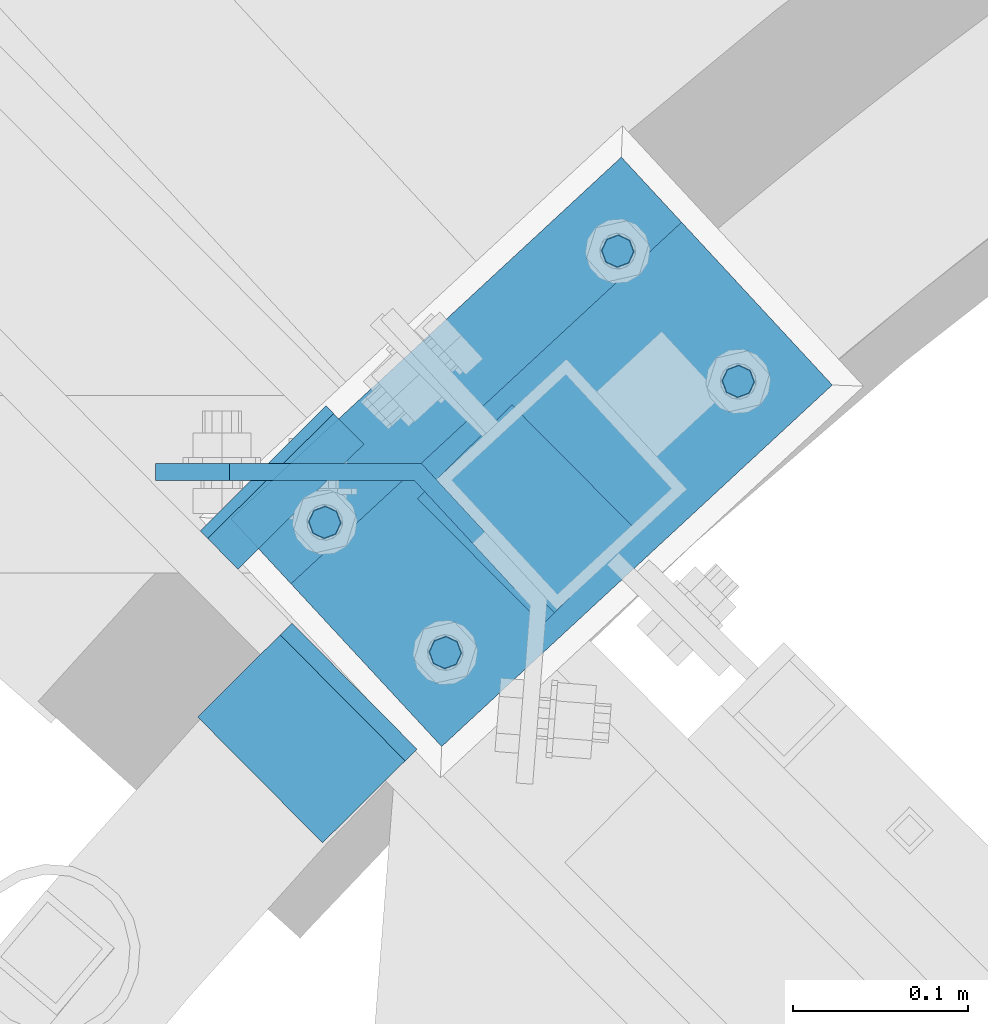
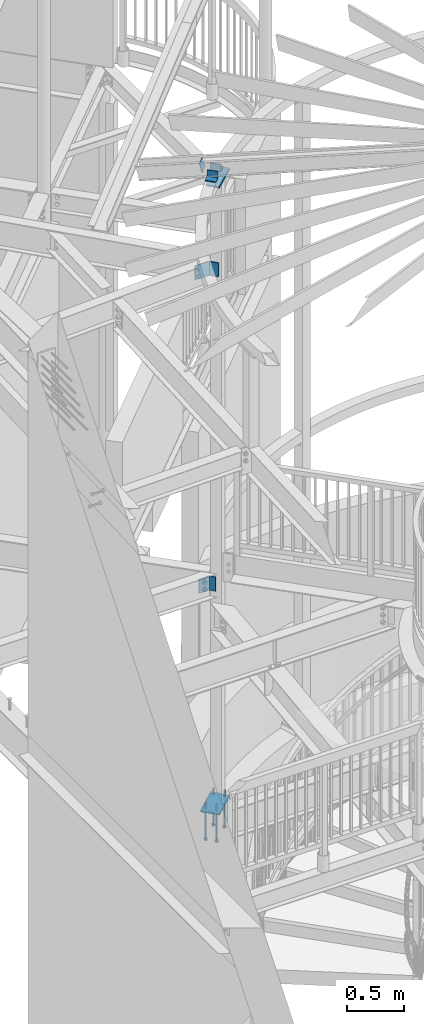
# One storey, part 485 of 975: 11 beams, 1 member.
"""IFC2X3 building model written with IfcOpenShell, lengths in millimetres."""

from ifc_helpers import new_model, si_unit, frame, origin_with_axes, place, context, subcontext, project, spatial, faceted_brep, material, type_object, element, save


model = new_model("IFC2X3")

# Units and contexts
model_context = context("Model", 3, precision=1e-05, world=origin_with_axes())
body_context = subcontext(model_context, "Body", "Model", "MODEL_VIEW")
ifc_project = project(units=[si_unit("LENGTHUNIT", "METRE", prefix="MILLI"), si_unit("AREAUNIT", "SQUARE_METRE"), si_unit("VOLUMEUNIT", "CUBIC_METRE"), si_unit("MASSUNIT", "GRAM", prefix="KILO"), si_unit("TIMEUNIT", "SECOND"), si_unit("PLANEANGLEUNIT", "RADIAN"), si_unit("SOLIDANGLEUNIT", "STERADIAN"), si_unit("THERMODYNAMICTEMPERATUREUNIT", "DEGREE_CELSIUS"), si_unit("LUMINOUSINTENSITYUNIT", "LUMEN")], contexts=[model_context])

# Site, building, storey
site_placement = place(None, origin_with_axes())
site = spatial("IfcSite", under=ifc_project, at=site_placement, CompositionType="ELEMENT")
building_placement = place(site_placement, origin_with_axes())
building = spatial("IfcBuilding", under=site, at=building_placement, Name="Undefined", CompositionType="ELEMENT")
storey_placement = place(building_placement, origin_with_axes())
storey = spatial("IfcBuildingStorey", under=building, at=storey_placement, Name="Undefined", CompositionType="ELEMENT", Elevation=0.0)

# Beams
ifc_material_1 = material(Name="STEEL/A36")
beam_type_1 = type_object("IfcBeamType", PredefinedType="NOTDEFINED")
beam_1_placement = place(storey_placement, frame((32474.3582621697, 5763.39354434329, 7213.59999999999), z_axis=(0.0, 0.0, 1.0), x_axis=(-0.679313234053475, 0.733848438057757, 0.0)))
element("IfcBeam", 1, at=beam_1_placement, inside=storey, type_object=beam_type_1, material=ifc_material_1, Name="BENT_PLATE", context=body_context, shape_type="Brep", body=[
    faceted_brep([(1.26819941215217e-07, -4.762500000008, -76.1999999999998), (1.26819941215217e-07, -4.762500000008, 76.1999999999998), (-1.26819941215217e-07, 4.76250000000437, 76.1999999999998), (-1.26819941215217e-07, 4.76250000000437, -76.1999999999998), (84.4832943958827, 4.76250015306869, 76.1999999999998), (84.4832943958827, 4.76250015306869, -76.1999999999998), (88.6456544859975, -4.76249983938033, -76.1999999999998), (88.6456544859975, -4.76249983938033, 76.1999999999998), (185.183083427983, 113.546458994399, 76.1999999999998), (185.183083427983, 113.546458994399, -76.1999999999998), (192.172989800485, 107.076000440029, 76.1999999999998), (192.172989800485, 107.076000440029, -76.1999999999998)], [[[0, 1, 2, 3]], [[3, 2, 4, 5]], [[1, 0, 6, 7]], [[5, 4, 8, 9]], [[4, 2, 1, 7, 10, 8]], [[7, 6, 11, 10]], [[6, 0, 3, 5, 9, 11]], [[10, 11, 9, 8]]]),
])
beam_2_placement = place(storey_placement, frame((32457.1037025236, 5782.03329466996, 3822.70000610352), z_axis=(0.0, 0.0, 1.0), x_axis=(-0.679313234053475, 0.733848438057757, 0.0)))
element("IfcBeam", 2, at=beam_2_placement, inside=storey, type_object=beam_type_1, material=ifc_material_1, Name="BENT_PLATE", context=body_context, shape_type="Brep", body=[
    faceted_brep([(1.26819941215217e-07, -4.762500000008, -76.1999999999998), (1.26819941215217e-07, -4.762500000008, 76.1999999999998), (-1.26819941215217e-07, 4.76250000000437, 76.1999999999998), (-1.26819941215217e-07, 4.76250000000437, -76.1999999999998), (59.0832973777142, 4.76249938950059, 76.1999999999998), (59.0832973777142, 4.76249938950059, -76.1999999999998), (63.2456574210337, -4.7625006534945, -76.1999999999998), (63.2456574210337, -4.7625006534945, 76.1999999999998), (131.040572859285, 82.4964983338759, 76.1999999999998), (131.040572859285, 82.4964983338759, -76.1999999999998), (138.03047923178, 76.0260397795137, 76.1999999999998), (138.03047923178, 76.0260397795137, -76.1999999999998)], [[[0, 1, 2, 3]], [[3, 2, 4, 5]], [[1, 0, 6, 7]], [[5, 4, 8, 9]], [[4, 2, 1, 7, 10, 8]], [[7, 6, 11, 10]], [[6, 0, 3, 5, 9, 11]], [[10, 11, 9, 8]]]),
])
beam_type_2 = type_object("IfcBeamType", Name="L3X3X3/8", PredefinedType="NOTDEFINED")
for number, where, z_axis, x_axis, name in (
    (3, (32388.0087970222, 5641.35428372317, 8318.5), (-0.709692888126233, -0.7045111812761, 5.71955752093346e-10), (-0.704511181200153, 0.709692888201625, 9.99996585988633e-10), "ANGLE"),
    (4, (32442.3841386058, 5838.49314316986, 8318.5), (0.709692888126235, 0.704511181276098, 5.71968485019169e-10), (0.704511181200146, -0.709692888201633, 9.99996585983236e-10), "ANGLE"),
):
    element("IfcBeam", number, at=place(storey_placement, frame(where, z_axis=z_axis, x_axis=x_axis)), inside=storey, type_object=beam_type_2, material=ifc_material_1, Name=name, ObjectType="L3X3X3/8", context=body_context, shape_type="Brep", body=[
        faceted_brep([(-6.18456397205591e-11, 38.0999999999876, -38.1000000000258), (1.45519152283669e-10, 38.1000000000295, 38.1000000000386), (101.599999999788, 38.1000000000004, 38.0999999999767), (101.599999999762, 38.1000000000004, -38.1000000000313), (4.72937244921923e-11, 28.5749999999316, 38.1), (101.599999999788, 28.5750000000007, 38.0999999999767), (4.72937244921923e-11, 28.5749999999316, -28.575), (101.599999999766, 28.5750000000007, -28.5750000000298), (-5.0931703299284e-11, -38.0999999999112, -28.575), (101.599999999766, -38.1000000000004, -28.5750000000298), (-1.41881173476577e-10, -38.1000000000258, -38.1000000000386), (101.599999999762, -38.1000000000004, -38.1000000000313)], [[[0, 1, 2, 3]], [[1, 4, 5, 2]], [[4, 6, 7, 5]], [[6, 8, 9, 7]], [[8, 10, 11, 9]], [[10, 0, 3, 11]], [[5, 7, 9, 11, 3, 2]], [[10, 8, 6, 4, 1, 0]]]),
    ])

# Member
member_type = type_object("IfcMemberType", PredefinedType="NOTDEFINED")
member_placement = place(storey_placement, frame((32346.4290549832, 5809.23530203269, 8306.81398391972), z_axis=(-0.709692888126233, -0.7045111812761, 5.71955752093346e-10), x_axis=(-0.170873527176511, 0.172130267177808, 0.970140922150774)))
element("IfcMember", 5, at=member_placement, inside=storey, type_object=member_type, material=ifc_material_1, Name="PLATE", context=body_context, shape_type="Brep", body=[
    faceted_brep([(0.0, 3.17499999999927, -50.7999999999993), (0.0, 3.17499999999109, 50.7999992370678), (101.600000000738, 3.17500000004657, 50.7999999999374), (101.600000000827, 3.17500000007567, -50.800000000112), (0.0, -3.17500000000882, 50.7999992370605), (101.60000000074, -3.17499999995562, 50.7999999999411), (0.0, -3.17499999999927, -50.7999999999993), (101.60000000083, -3.17499999993379, -50.8000000001084)], [[[0, 1, 2, 3]], [[1, 4, 5, 2]], [[4, 6, 7, 5]], [[6, 0, 3, 7]], [[5, 7, 3, 2]], [[6, 4, 1, 0]]]),
])

# Beams
beam_type_3 = type_object("IfcBeamType", PredefinedType="NOTDEFINED")
beam_3_placement = place(storey_placement, frame((32386.0396579057, 5716.25029936759, 8170.8625), z_axis=(0.679313234053469, -0.733848438057762, 0.0), x_axis=(0.733848438057782, 0.679313234053447, 0.0)))
element("IfcBeam", 6, at=beam_3_placement, inside=storey, type_object=beam_type_3, material=ifc_material_1, Name="PLATE", context=body_context, shape_type="Brep", body=[
    faceted_brep([(0.0, 7.9375, -63.5), (0.0, 7.9375, 63.5), (304.799999999529, 7.9375, 63.5), (304.799999999529, 7.9375, -63.5), (0.0, -7.9375, 63.5), (304.799999999529, -7.9375, 63.5), (0.0, -7.9375, -63.5), (304.799999999529, -7.9375, -63.5)], [[[0, 1, 2, 3]], [[1, 4, 5, 2]], [[4, 6, 7, 5]], [[6, 0, 3, 7]], [[5, 7, 3, 2]], [[6, 4, 1, 0]]]),
])
ifc_material_2 = material(Name="STEEL/F1554-36")
beam_type_4 = type_object("IfcBeamType", PredefinedType="NOTDEFINED")
beam_4_placement = place(storey_placement, frame((32599.0115969585, 5878.78339270907, 1371.6), z_axis=(0.733848438057782, 0.679313234053447, 0.0), x_axis=(0.0, 0.0, -1.0)))
element("IfcBeam", 7, at=beam_4_placement, inside=storey, type_object=beam_type_4, material=ifc_material_2, Name="HEADED_ANCHOR_BOLT", context=body_context, shape_type="Brep", body=[
    faceted_brep([(260.34375, -9.13000011445183, 15.8100004195221), (260.34375, -18.2600002289691, -1.45519152283669e-11), (279.393749999999, -18.2600002289691, -1.45519152283669e-11), (279.393749999999, -9.13000011445183, 15.8100004195221), (260.34375, 9.13000011451732, 15.8100004195403), (279.393749999999, 9.13000011451732, 15.8100004195403), (260.34375, 18.2600002289728, 1.81898940354586e-11), (279.393749999999, 18.2600002289728, 1.81898940354586e-11), (260.34375, 9.13000011445547, -15.8100004195221), (279.393749999999, 9.13000011445547, -15.8100004195221), (260.34375, -9.13000011451732, -15.8100004195367), (279.393749999999, -9.13000011451732, -15.8100004195367), (260.34375, -4.47768005528269, 9.29799844174704), (260.34375, -8.06850066050174, 6.43441456486471), (260.34375, -10.0612557562381, 2.29641597050068), (260.34375, -10.0612557562454, -2.29641597051523), (260.34375, -8.06850066052721, -6.43441456487926), (260.34375, -4.47768005531907, -9.29799844175068), (260.34375, -1.81898940354586e-11, -10.319999694766), (260.34375, 4.47768005528633, -9.2979984417434), (260.34375, 8.06850066050174, -6.43441456486471), (260.34375, 10.0612557562381, -2.29641597050068), (260.34375, 10.0612557562454, 2.29641597051886), (260.34375, 8.06850066052357, 6.4344145648829), (260.34375, 4.47768005532271, 9.29799844175432), (260.34375, 2.18278728425503e-11, 10.3199996947696), (279.393749999999, 2.18278728425503e-11, 10.3199996947696), (279.393749999999, -4.47768005528269, 9.29799844174704), (279.393749999999, -8.06850066050174, 6.43441456486471), (279.393749999999, -10.0612557562381, 2.29641597050068), (279.393749999999, -10.0612557562454, -2.29641597051523), (279.393749999999, -8.06850066052721, -6.43441456487926), (279.393749999999, -4.47768005531907, -9.29799844175068), (279.393749999999, -1.81898940354586e-11, -10.319999694766), (279.393749999999, 4.47768005528633, -9.2979984417434), (279.393749999999, 8.06850066050174, -6.43441456486471), (279.393749999999, 10.0612557562381, -2.29641597050068), (279.393749999999, 10.0612557562454, 2.29641597051886), (279.393749999999, 8.06850066052357, 6.4344145648829), (279.393749999999, 4.47768005532271, 9.29799844175432), (0.0, -6.73519209080223, 6.73519209080186), (0.0, -9.52499999999964, 0.0), (279.400000000001, -9.52499999999782, -3.63797880709171e-12), (279.400000000001, -6.73519209079313, 6.73519209079313), (-9.87109982941227e-13, -1.20792265079217e-13, 9.52499961853027), (279.400000000001, 1.09139364212751e-11, 9.52499999999054), (0.0, 6.73519209080223, 6.73519209080186), (279.400000000001, 6.73519209081132, 6.73519209079677), (0.0, 9.52499999999964, 0.0), (279.400000000001, 9.52500000000146, 3.63797880709171e-12), (0.0, 6.73519209080223, -6.73519209080186), (279.400000000001, 6.73519209079677, -6.73519209079313), (2.95075507493764e-12, -1.20792265079217e-13, -9.52499961853027), (279.400000000001, -1.09139364212751e-11, -9.5249999999869), (-126.99791499542, -6.36396103070001, 6.3639610306418), (-126.99791499542, 1.81898940354586e-11, 8.99999999995271), (-126.99791499542, 6.36396103072184, 6.36396103065272), (-126.99791499542, 9.00000000004366, 1.09139364212751e-11), (-126.99791499542, 6.36396103069637, -6.3639610306418), (-126.99791499542, -1.81898940354586e-11, -8.99999999995271), (-126.99791499542, -6.36396103072184, -6.36396103064908), (-126.99791499542, -9.00000000004002, -7.27595761418343e-12), (0.0149743263646087, 6.36396103067818, -6.36396103067909), (0.0149743263646087, 0.0, -9.0), (0.0149743263646087, -6.36396103067818, -6.36396103067909), (0.0149743263987148, -8.9999995411581, -1.00796984270346e-06), (0.0149743263646087, -6.36396103067818, 6.36396103067909), (0.0149743263646087, 0.0, 9.0), (0.0149743263646087, 6.36396103067818, 6.36396103067909), (0.0149743263987148, 9.0000004588419, -1.00796984270346e-06), (0.0, -6.73519209080223, -6.73519209080186), (279.400000000001, -6.73519209080769, -6.73519209079677)], [[[0, 1, 2, 3]], [[4, 0, 3, 5]], [[6, 4, 5, 7]], [[8, 6, 7, 9]], [[10, 8, 9, 11]], [[0, 4, 6, 8, 10, 1], [12, 13, 14, 15, 16, 17, 18, 19, 20, 21, 22, 23, 24, 25]], [[12, 25, 26, 27]], [[13, 12, 27, 28]], [[14, 13, 28, 29]], [[15, 14, 29, 30]], [[16, 15, 30, 31]], [[17, 16, 31, 32]], [[18, 17, 32, 33]], [[19, 18, 33, 34]], [[20, 19, 34, 35]], [[21, 20, 35, 36]], [[22, 21, 36, 37]], [[23, 22, 37, 38]], [[24, 23, 38, 39]], [[25, 24, 39, 26]], [[9, 7, 5, 3, 2, 11], [38, 37, 36, 35, 34, 33, 32, 31, 30, 29, 28, 27, 26, 39]], [[1, 10, 11, 2]], [[40, 41, 42, 43]], [[44, 40, 43, 45]], [[46, 44, 45, 47]], [[48, 46, 47, 49]], [[50, 48, 49, 51]], [[52, 50, 51, 53]], [[54, 55, 56, 57, 58, 59, 60, 61]], [[59, 58, 62, 63]], [[60, 59, 63, 64]], [[61, 60, 64, 65]], [[54, 61, 65, 66]], [[55, 54, 66, 67]], [[56, 55, 67, 68]], [[57, 56, 68, 69]], [[58, 57, 69, 62]], [[40, 44, 46, 48, 50, 52, 70, 41], [68, 67, 66, 65, 64, 63, 62, 69]], [[41, 70, 71, 42]], [[53, 51, 49, 47, 45, 43, 42, 71]], [[70, 52, 53, 71]]]),
])
beam_5_placement = place(storey_placement, frame((32529.9933678984, 5953.34238986853, 1371.6), z_axis=(-0.733848438057767, -0.679313234053464, 0.0), x_axis=(0.0, 0.0, -1.0)))
element("IfcBeam", 8, at=beam_5_placement, inside=storey, type_object=beam_type_4, material=ifc_material_2, Name="HEADED_ANCHOR_BOLT", context=body_context, shape_type="Brep", body=[
    faceted_brep([(260.34375, -9.13000011445183, 15.8100004195221), (260.34375, -18.2600002289691, -1.45519152283669e-11), (279.393749999999, -18.2600002289691, -1.45519152283669e-11), (279.393749999999, -9.13000011445183, 15.8100004195221), (260.34375, 9.13000011451732, 15.8100004195403), (279.393749999999, 9.13000011451732, 15.8100004195403), (260.34375, 18.2600002289728, 1.81898940354586e-11), (279.393749999999, 18.2600002289728, 1.81898940354586e-11), (260.34375, 9.13000011445547, -15.8100004195221), (279.393749999999, 9.13000011445547, -15.8100004195221), (260.34375, -9.13000011451732, -15.8100004195367), (279.393749999999, -9.13000011451732, -15.8100004195367), (260.34375, -4.47768005528269, 9.29799844174704), (260.34375, -8.06850066050174, 6.43441456486471), (260.34375, -10.0612557562381, 2.29641597050068), (260.34375, -10.0612557562454, -2.29641597051523), (260.34375, -8.06850066052721, -6.43441456487926), (260.34375, -4.47768005531907, -9.29799844175068), (260.34375, -1.81898940354586e-11, -10.319999694766), (260.34375, 4.47768005528633, -9.2979984417434), (260.34375, 8.06850066050174, -6.43441456486471), (260.34375, 10.0612557562381, -2.29641597050068), (260.34375, 10.0612557562454, 2.29641597051886), (260.34375, 8.06850066052357, 6.4344145648829), (260.34375, 4.47768005532271, 9.29799844175432), (260.34375, 2.18278728425503e-11, 10.3199996947696), (279.393749999999, 2.18278728425503e-11, 10.3199996947696), (279.393749999999, -4.47768005528269, 9.29799844174704), (279.393749999999, -8.06850066050174, 6.43441456486471), (279.393749999999, -10.0612557562381, 2.29641597050068), (279.393749999999, -10.0612557562454, -2.29641597051523), (279.393749999999, -8.06850066052721, -6.43441456487926), (279.393749999999, -4.47768005531907, -9.29799844175068), (279.393749999999, -1.81898940354586e-11, -10.319999694766), (279.393749999999, 4.47768005528633, -9.2979984417434), (279.393749999999, 8.06850066050174, -6.43441456486471), (279.393749999999, 10.0612557562381, -2.29641597050068), (279.393749999999, 10.0612557562454, 2.29641597051886), (279.393749999999, 8.06850066052357, 6.4344145648829), (279.393749999999, 4.47768005532271, 9.29799844175432), (0.0, -6.73519209080223, 6.73519209080186), (0.0, -9.52499999999964, 0.0), (279.400000000001, -9.52499999999782, -3.63797880709171e-12), (279.400000000001, -6.73519209079313, 6.73519209079313), (-9.87109982941227e-13, -1.20792265079217e-13, 9.52499961853027), (279.400000000001, 1.09139364212751e-11, 9.52499999999054), (0.0, 6.73519209080223, 6.73519209080186), (279.400000000001, 6.73519209081132, 6.73519209079677), (0.0, 9.52499999999964, 0.0), (279.400000000001, 9.52500000000146, 3.63797880709171e-12), (0.0, 6.73519209080223, -6.73519209080186), (279.400000000001, 6.73519209079677, -6.73519209079313), (2.95075507493764e-12, -1.20792265079217e-13, -9.52499961853027), (279.400000000001, -1.09139364212751e-11, -9.5249999999869), (-126.99791499542, -6.36396103070001, 6.3639610306418), (-126.99791499542, 1.81898940354586e-11, 8.99999999995271), (-126.99791499542, 6.36396103072184, 6.36396103065272), (-126.99791499542, 9.00000000004366, 1.09139364212751e-11), (-126.99791499542, 6.36396103069637, -6.3639610306418), (-126.99791499542, -1.81898940354586e-11, -8.99999999995271), (-126.99791499542, -6.36396103072184, -6.36396103064908), (-126.99791499542, -9.00000000004002, -7.27595761418343e-12), (0.0149743263646087, 6.36396103067818, -6.36396103067909), (0.0149743263646087, 0.0, -9.0), (0.0149743263646087, -6.36396103067818, -6.36396103067909), (0.0149743263987148, -8.9999995411581, -1.00796984270346e-06), (0.0149743263646087, -6.36396103067818, 6.36396103067909), (0.0149743263646087, 0.0, 9.0), (0.0149743263646087, 6.36396103067818, 6.36396103067909), (0.0149743263987148, 9.0000004588419, -1.00796984270346e-06), (0.0, -6.73519209080223, -6.73519209080186), (279.400000000001, -6.73519209080769, -6.73519209079677)], [[[0, 1, 2, 3]], [[4, 0, 3, 5]], [[6, 4, 5, 7]], [[8, 6, 7, 9]], [[10, 8, 9, 11]], [[0, 4, 6, 8, 10, 1], [12, 13, 14, 15, 16, 17, 18, 19, 20, 21, 22, 23, 24, 25]], [[12, 25, 26, 27]], [[13, 12, 27, 28]], [[14, 13, 28, 29]], [[15, 14, 29, 30]], [[16, 15, 30, 31]], [[17, 16, 31, 32]], [[18, 17, 32, 33]], [[19, 18, 33, 34]], [[20, 19, 34, 35]], [[21, 20, 35, 36]], [[22, 21, 36, 37]], [[23, 22, 37, 38]], [[24, 23, 38, 39]], [[25, 24, 39, 26]], [[9, 7, 5, 3, 2, 11], [38, 37, 36, 35, 34, 33, 32, 31, 30, 29, 28, 27, 26, 39]], [[1, 10, 11, 2]], [[40, 41, 42, 43]], [[44, 40, 43, 45]], [[46, 44, 45, 47]], [[48, 46, 47, 49]], [[50, 48, 49, 51]], [[52, 50, 51, 53]], [[54, 55, 56, 57, 58, 59, 60, 61]], [[59, 58, 62, 63]], [[60, 59, 63, 64]], [[61, 60, 64, 65]], [[54, 61, 65, 66]], [[55, 54, 66, 67]], [[56, 55, 67, 68]], [[57, 56, 68, 69]], [[58, 57, 69, 62]], [[40, 44, 46, 48, 50, 52, 70, 41], [68, 67, 66, 65, 64, 63, 62, 69]], [[41, 70, 71, 42]], [[53, 51, 49, 47, 45, 43, 42, 71]], [[70, 52, 53, 71]]]),
])
beam_6_placement = place(storey_placement, frame((32431.2538440184, 5723.49238740398, 1371.6), z_axis=(0.733848438057782, 0.679313234053447, 0.0), x_axis=(0.0, 0.0, -1.0)))
element("IfcBeam", 9, at=beam_6_placement, inside=storey, type_object=beam_type_4, material=ifc_material_2, Name="HEADED_ANCHOR_BOLT", context=body_context, shape_type="Brep", body=[
    faceted_brep([(260.34375, -9.13000011445183, 15.8100004195221), (260.34375, -18.2600002289691, -1.45519152283669e-11), (279.393749999999, -18.2600002289691, -1.45519152283669e-11), (279.393749999999, -9.13000011445183, 15.8100004195221), (260.34375, 9.13000011451732, 15.8100004195403), (279.393749999999, 9.13000011451732, 15.8100004195403), (260.34375, 18.2600002289728, 1.81898940354586e-11), (279.393749999999, 18.2600002289728, 1.81898940354586e-11), (260.34375, 9.13000011445547, -15.8100004195221), (279.393749999999, 9.13000011445547, -15.8100004195221), (260.34375, -9.13000011451732, -15.8100004195367), (279.393749999999, -9.13000011451732, -15.8100004195367), (260.34375, -4.47768005528269, 9.29799844174704), (260.34375, -8.06850066050174, 6.43441456486471), (260.34375, -10.0612557562381, 2.29641597050068), (260.34375, -10.0612557562454, -2.29641597051523), (260.34375, -8.06850066052721, -6.43441456487926), (260.34375, -4.47768005531907, -9.29799844175068), (260.34375, -1.81898940354586e-11, -10.319999694766), (260.34375, 4.47768005528633, -9.2979984417434), (260.34375, 8.06850066050174, -6.43441456486471), (260.34375, 10.0612557562381, -2.29641597050068), (260.34375, 10.0612557562454, 2.29641597051886), (260.34375, 8.06850066052357, 6.4344145648829), (260.34375, 4.47768005532271, 9.29799844175432), (260.34375, 2.18278728425503e-11, 10.3199996947696), (279.393749999999, 2.18278728425503e-11, 10.3199996947696), (279.393749999999, -4.47768005528269, 9.29799844174704), (279.393749999999, -8.06850066050174, 6.43441456486471), (279.393749999999, -10.0612557562381, 2.29641597050068), (279.393749999999, -10.0612557562454, -2.29641597051523), (279.393749999999, -8.06850066052721, -6.43441456487926), (279.393749999999, -4.47768005531907, -9.29799844175068), (279.393749999999, -1.81898940354586e-11, -10.319999694766), (279.393749999999, 4.47768005528633, -9.2979984417434), (279.393749999999, 8.06850066050174, -6.43441456486471), (279.393749999999, 10.0612557562381, -2.29641597050068), (279.393749999999, 10.0612557562454, 2.29641597051886), (279.393749999999, 8.06850066052357, 6.4344145648829), (279.393749999999, 4.47768005532271, 9.29799844175432), (0.0, -6.73519209080223, 6.73519209080186), (0.0, -9.52499999999964, 0.0), (279.400000000001, -9.52499999999782, -3.63797880709171e-12), (279.400000000001, -6.73519209079313, 6.73519209079313), (-9.87109982941227e-13, -1.20792265079217e-13, 9.52499961853027), (279.400000000001, 1.09139364212751e-11, 9.52499999999054), (0.0, 6.73519209080223, 6.73519209080186), (279.400000000001, 6.73519209081132, 6.73519209079677), (0.0, 9.52499999999964, 0.0), (279.400000000001, 9.52500000000146, 3.63797880709171e-12), (0.0, 6.73519209080223, -6.73519209080186), (279.400000000001, 6.73519209079677, -6.73519209079313), (2.95075507493764e-12, -1.20792265079217e-13, -9.52499961853027), (279.400000000001, -1.09139364212751e-11, -9.5249999999869), (-126.99791499542, -6.36396103070001, 6.3639610306418), (-126.99791499542, 1.81898940354586e-11, 8.99999999995271), (-126.99791499542, 6.36396103072184, 6.36396103065272), (-126.99791499542, 9.00000000004366, 1.09139364212751e-11), (-126.99791499542, 6.36396103069637, -6.3639610306418), (-126.99791499542, -1.81898940354586e-11, -8.99999999995271), (-126.99791499542, -6.36396103072184, -6.36396103064908), (-126.99791499542, -9.00000000004002, -7.27595761418343e-12), (0.0149743263646087, 6.36396103067818, -6.36396103067909), (0.0149743263646087, 0.0, -9.0), (0.0149743263646087, -6.36396103067818, -6.36396103067909), (0.0149743263987148, -8.9999995411581, -1.00796984270346e-06), (0.0149743263646087, -6.36396103067818, 6.36396103067909), (0.0149743263646087, 0.0, 9.0), (0.0149743263646087, 6.36396103067818, 6.36396103067909), (0.0149743263987148, 9.0000004588419, -1.00796984270346e-06), (0.0, -6.73519209080223, -6.73519209080186), (279.400000000001, -6.73519209080769, -6.73519209079677)], [[[0, 1, 2, 3]], [[4, 0, 3, 5]], [[6, 4, 5, 7]], [[8, 6, 7, 9]], [[10, 8, 9, 11]], [[0, 4, 6, 8, 10, 1], [12, 13, 14, 15, 16, 17, 18, 19, 20, 21, 22, 23, 24, 25]], [[12, 25, 26, 27]], [[13, 12, 27, 28]], [[14, 13, 28, 29]], [[15, 14, 29, 30]], [[16, 15, 30, 31]], [[17, 16, 31, 32]], [[18, 17, 32, 33]], [[19, 18, 33, 34]], [[20, 19, 34, 35]], [[21, 20, 35, 36]], [[22, 21, 36, 37]], [[23, 22, 37, 38]], [[24, 23, 38, 39]], [[25, 24, 39, 26]], [[9, 7, 5, 3, 2, 11], [38, 37, 36, 35, 34, 33, 32, 31, 30, 29, 28, 27, 26, 39]], [[1, 10, 11, 2]], [[40, 41, 42, 43]], [[44, 40, 43, 45]], [[46, 44, 45, 47]], [[48, 46, 47, 49]], [[50, 48, 49, 51]], [[52, 50, 51, 53]], [[54, 55, 56, 57, 58, 59, 60, 61]], [[59, 58, 62, 63]], [[60, 59, 63, 64]], [[61, 60, 64, 65]], [[54, 61, 65, 66]], [[55, 54, 66, 67]], [[56, 55, 67, 68]], [[57, 56, 68, 69]], [[58, 57, 69, 62]], [[40, 44, 46, 48, 50, 52, 70, 41], [68, 67, 66, 65, 64, 63, 62, 69]], [[41, 70, 71, 42]], [[53, 51, 49, 47, 45, 43, 42, 71]], [[70, 52, 53, 71]]]),
])
beam_7_placement = place(storey_placement, frame((32362.2356149595, 5798.05138456452, 1371.6), z_axis=(-0.733848438057767, -0.679313234053464, 0.0), x_axis=(0.0, 0.0, -1.0)))
element("IfcBeam", 10, at=beam_7_placement, inside=storey, type_object=beam_type_4, material=ifc_material_2, Name="HEADED_ANCHOR_BOLT", context=body_context, shape_type="Brep", body=[
    faceted_brep([(260.34375, -9.13000011445183, 15.8100004195221), (260.34375, -18.2600002289691, -1.45519152283669e-11), (279.393749999999, -18.2600002289691, -1.45519152283669e-11), (279.393749999999, -9.13000011445183, 15.8100004195221), (260.34375, 9.13000011451732, 15.8100004195403), (279.393749999999, 9.13000011451732, 15.8100004195403), (260.34375, 18.2600002289728, 1.81898940354586e-11), (279.393749999999, 18.2600002289728, 1.81898940354586e-11), (260.34375, 9.13000011445547, -15.8100004195221), (279.393749999999, 9.13000011445547, -15.8100004195221), (260.34375, -9.13000011451732, -15.8100004195367), (279.393749999999, -9.13000011451732, -15.8100004195367), (260.34375, -4.47768005528269, 9.29799844174704), (260.34375, -8.06850066050174, 6.43441456486471), (260.34375, -10.0612557562381, 2.29641597050068), (260.34375, -10.0612557562454, -2.29641597051523), (260.34375, -8.06850066052721, -6.43441456487926), (260.34375, -4.47768005531907, -9.29799844175068), (260.34375, -1.81898940354586e-11, -10.319999694766), (260.34375, 4.47768005528633, -9.2979984417434), (260.34375, 8.06850066050174, -6.43441456486471), (260.34375, 10.0612557562381, -2.29641597050068), (260.34375, 10.0612557562454, 2.29641597051886), (260.34375, 8.06850066052357, 6.4344145648829), (260.34375, 4.47768005532271, 9.29799844175432), (260.34375, 2.18278728425503e-11, 10.3199996947696), (279.393749999999, 2.18278728425503e-11, 10.3199996947696), (279.393749999999, -4.47768005528269, 9.29799844174704), (279.393749999999, -8.06850066050174, 6.43441456486471), (279.393749999999, -10.0612557562381, 2.29641597050068), (279.393749999999, -10.0612557562454, -2.29641597051523), (279.393749999999, -8.06850066052721, -6.43441456487926), (279.393749999999, -4.47768005531907, -9.29799844175068), (279.393749999999, -1.81898940354586e-11, -10.319999694766), (279.393749999999, 4.47768005528633, -9.2979984417434), (279.393749999999, 8.06850066050174, -6.43441456486471), (279.393749999999, 10.0612557562381, -2.29641597050068), (279.393749999999, 10.0612557562454, 2.29641597051886), (279.393749999999, 8.06850066052357, 6.4344145648829), (279.393749999999, 4.47768005532271, 9.29799844175432), (0.0, -6.73519209080223, 6.73519209080186), (0.0, -9.52499999999964, 0.0), (279.400000000001, -9.52499999999782, -3.63797880709171e-12), (279.400000000001, -6.73519209079313, 6.73519209079313), (-9.87109982941227e-13, -1.20792265079217e-13, 9.52499961853027), (279.400000000001, 1.09139364212751e-11, 9.52499999999054), (0.0, 6.73519209080223, 6.73519209080186), (279.400000000001, 6.73519209081132, 6.73519209079677), (0.0, 9.52499999999964, 0.0), (279.400000000001, 9.52500000000146, 3.63797880709171e-12), (0.0, 6.73519209080223, -6.73519209080186), (279.400000000001, 6.73519209079677, -6.73519209079313), (2.95075507493764e-12, -1.20792265079217e-13, -9.52499961853027), (279.400000000001, -1.09139364212751e-11, -9.5249999999869), (-126.99791499542, -6.36396103070001, 6.3639610306418), (-126.99791499542, 1.81898940354586e-11, 8.99999999995271), (-126.99791499542, 6.36396103072184, 6.36396103065272), (-126.99791499542, 9.00000000004366, 1.09139364212751e-11), (-126.99791499542, 6.36396103069637, -6.3639610306418), (-126.99791499542, -1.81898940354586e-11, -8.99999999995271), (-126.99791499542, -6.36396103072184, -6.36396103064908), (-126.99791499542, -9.00000000004002, -7.27595761418343e-12), (0.0149743263646087, 6.36396103067818, -6.36396103067909), (0.0149743263646087, 0.0, -9.0), (0.0149743263646087, -6.36396103067818, -6.36396103067909), (0.0149743263987148, -8.9999995411581, -1.00796984270346e-06), (0.0149743263646087, -6.36396103067818, 6.36396103067909), (0.0149743263646087, 0.0, 9.0), (0.0149743263646087, 6.36396103067818, 6.36396103067909), (0.0149743263987148, 9.0000004588419, -1.00796984270346e-06), (0.0, -6.73519209080223, -6.73519209080186), (279.400000000001, -6.73519209080769, -6.73519209079677)], [[[0, 1, 2, 3]], [[4, 0, 3, 5]], [[6, 4, 5, 7]], [[8, 6, 7, 9]], [[10, 8, 9, 11]], [[0, 4, 6, 8, 10, 1], [12, 13, 14, 15, 16, 17, 18, 19, 20, 21, 22, 23, 24, 25]], [[12, 25, 26, 27]], [[13, 12, 27, 28]], [[14, 13, 28, 29]], [[15, 14, 29, 30]], [[16, 15, 30, 31]], [[17, 16, 31, 32]], [[18, 17, 32, 33]], [[19, 18, 33, 34]], [[20, 19, 34, 35]], [[21, 20, 35, 36]], [[22, 21, 36, 37]], [[23, 22, 37, 38]], [[24, 23, 38, 39]], [[25, 24, 39, 26]], [[9, 7, 5, 3, 2, 11], [38, 37, 36, 35, 34, 33, 32, 31, 30, 29, 28, 27, 26, 39]], [[1, 10, 11, 2]], [[40, 41, 42, 43]], [[44, 40, 43, 45]], [[46, 44, 45, 47]], [[48, 46, 47, 49]], [[50, 48, 49, 51]], [[52, 50, 51, 53]], [[54, 55, 56, 57, 58, 59, 60, 61]], [[59, 58, 62, 63]], [[60, 59, 63, 64]], [[61, 60, 64, 65]], [[54, 61, 65, 66]], [[55, 54, 66, 67]], [[56, 55, 67, 68]], [[57, 56, 68, 69]], [[58, 57, 69, 62]], [[40, 44, 46, 48, 50, 52, 70, 41], [68, 67, 66, 65, 64, 63, 62, 69]], [[41, 70, 71, 42]], [[53, 51, 49, 47, 45, 43, 42, 71]], [[70, 52, 53, 71]]]),
])
beam_type_5 = type_object("IfcBeamType", PredefinedType="NOTDEFINED")
beam_8_placement = place(storey_placement, frame((32368.7851017596, 5734.89004969368, 1419.225), z_axis=(-0.679313234053475, 0.733848438057757, 0.0), x_axis=(0.733848438057782, 0.679313234053447, 0.0)))
element("IfcBeam", 11, at=beam_8_placement, inside=storey, type_object=beam_type_5, material=ifc_material_1, Name="PLATE", context=body_context, shape_type="Brep", body=[
    faceted_brep([(0.0, 9.52499999999964, -88.9000000000015), (0.0, 9.52499999999964, 88.9000000000015), (304.800000000429, 9.52500000000009, 88.9000000003653), (304.800000000414, 9.52500000000009, -88.8999999996704), (0.0, -9.52499999999964, 88.9000000000015), (304.800000000429, -9.52500000000009, 88.9000000003653), (0.0, -9.52499999999964, -88.9000000000015), (304.800000000414, -9.52500000000009, -88.8999999996704)], [[[0, 1, 2, 3]], [[1, 4, 5, 2]], [[4, 6, 7, 5]], [[6, 0, 3, 7]], [[5, 7, 3, 2]], [[6, 4, 1, 0]]]),
])
beam_type_6 = type_object("IfcBeamType", PredefinedType="NOTDEFINED")
beam_9_placement = place(storey_placement, frame((32368.7851017596, 5734.89004969382, 1411.2875), z_axis=(-0.679313234053475, 0.733848438057757, 0.0), x_axis=(0.733848438057782, 0.679313234053447, 0.0)))
element("IfcBeam", 12, at=beam_9_placement, inside=storey, type_object=beam_type_6, material=ifc_material_1, Name="TEMPLATE", context=body_context, shape_type="Brep", body=[
    faceted_brep([(-1.09139364212751e-11, 1.58750000000009, -88.900000000016), (3.63797880709171e-12, 1.58750000000009, 88.9000000000196), (304.800000000418, 1.58750000000009, 88.9000000003762), (304.800000000399, 1.58750000000009, -88.8999999996631), (3.63797880709171e-12, -1.58750000000009, 88.9000000000196), (304.800000000418, -1.58750000000009, 88.9000000003762), (-1.09139364212751e-11, -1.58750000000009, -88.900000000016), (304.800000000399, -1.58750000000009, -88.8999999996631)], [[[0, 1, 2, 3]], [[1, 4, 5, 2]], [[4, 6, 7, 5]], [[6, 0, 3, 7]], [[5, 7, 3, 2]], [[6, 4, 1, 0]]]),
])

save(model, "model.ifc")
